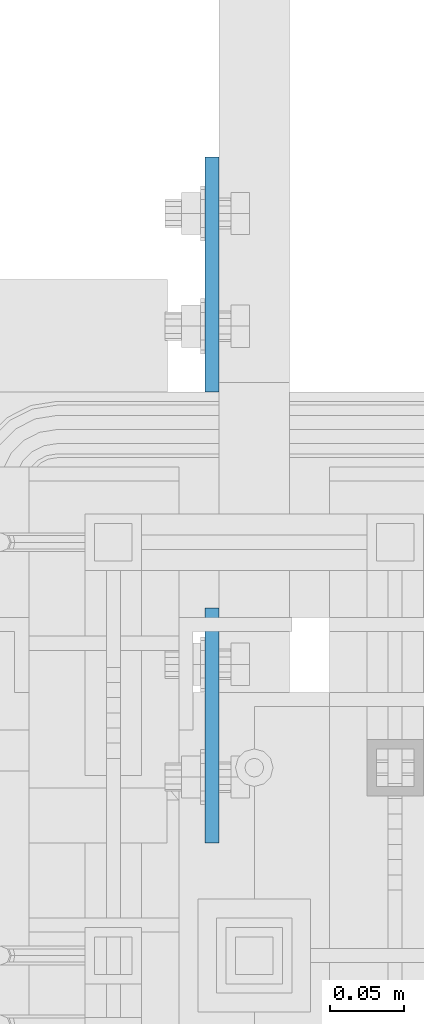
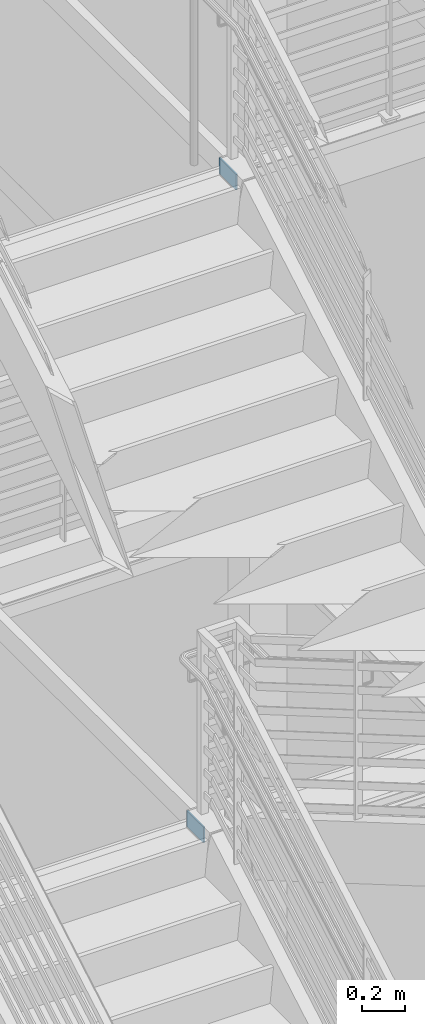
# One storey, part 1056 of 1179: 2 plates, 2 elements without a shape of their own.
"""IFC2X3 building model written with IfcOpenShell, lengths in millimetres."""

from ifc_helpers import new_model, si_unit, frame, origin_with_axes, place, context, subcontext, project, spatial, faceted_brep, material, type_object, element, aggregate, save


model = new_model("IFC2X3")

# Units and contexts
model_context = context("Model", 3, precision=1e-05, world=origin_with_axes())
body_context = subcontext(model_context, "Body", "Model", "MODEL_VIEW")
ifc_project = project(units=[si_unit("LENGTHUNIT", "METRE", prefix="MILLI"), si_unit("AREAUNIT", "SQUARE_METRE"), si_unit("VOLUMEUNIT", "CUBIC_METRE"), si_unit("MASSUNIT", "GRAM", prefix="KILO"), si_unit("TIMEUNIT", "SECOND"), si_unit("PLANEANGLEUNIT", "RADIAN"), si_unit("SOLIDANGLEUNIT", "STERADIAN"), si_unit("THERMODYNAMICTEMPERATUREUNIT", "DEGREE_CELSIUS"), si_unit("LUMINOUSINTENSITYUNIT", "LUMEN")], contexts=[model_context])

# Site, building, storey
site_placement = place(None, origin_with_axes())
site = spatial("IfcSite", under=ifc_project, at=site_placement, CompositionType="ELEMENT")
building_placement = place(site_placement, origin_with_axes())
building = spatial("IfcBuilding", under=site, at=building_placement, Name="Undefined", CompositionType="ELEMENT")
storey_placement = place(building_placement, origin_with_axes())
storey = spatial("IfcBuildingStorey", under=building, at=storey_placement, Name="Undefined", CompositionType="ELEMENT", Elevation=0.0)

# Assembly, plate
assembly_1_placement = place(storey_placement, origin_with_axes())
assembly_1 = element("IfcElementAssembly", 1, at=assembly_1_placement, inside=storey, Name="BEAM", AssemblyPlace="NOTDEFINED", PredefinedType="RIGID_FRAME")
ifc_material = material(Name="STEEL/A36")
plate_type = type_object("IfcPlateType", PredefinedType="NOTDEFINED")
plate_1_placement = place(assembly_1_placement, frame((-1781.175, 35496.5000000027, 4114.8), z_axis=(0.0, 1.0, 0.0), x_axis=(0.0, 0.0, -1.0)))
plate_1 = element("IfcPlate", 2, at=plate_1_placement, type_object=plate_type, material=ifc_material, Name="PLATE", context=body_context, shape_type="Brep", body=[
    faceted_brep([(0.0, -4.76249999999709, 0.0), (0.0, -4.76250000000005, 158.75), (0.0, 4.76250000000005, 158.75), (0.0, 4.76249999999709, 0.0), (88.8999999999996, -4.76250000000005, 158.75), (88.8999999999996, 4.76250000000005, 158.75), (88.8999999999996, -4.76250000000005, 0.0), (88.8999999999996, 4.76250000000005, 0.0)], [[[0, 1, 2, 3]], [[1, 4, 5, 2]], [[4, 6, 7, 5]], [[6, 0, 3, 7]], [[5, 7, 3, 2]], [[6, 4, 1, 0]]]),
])
aggregate(assembly_1, [plate_1])

assembly_2_placement = place(storey_placement, origin_with_axes())
assembly_2 = element("IfcElementAssembly", 3, at=assembly_2_placement, inside=storey, Name="BEAM", AssemblyPlace="NOTDEFINED", PredefinedType="RIGID_FRAME")
plate_2_placement = place(assembly_2_placement, frame((-1781.175, 35191.7, 8026.4), z_axis=(0.0, 1.0, 0.0), x_axis=(0.0, 0.0, -1.0)))
plate_2 = element("IfcPlate", 4, at=plate_2_placement, type_object=plate_type, material=ifc_material, Name="PLATE", context=body_context, shape_type="Brep", body=[
    faceted_brep([(0.0, -4.76249999999709, 0.0), (0.0, -4.76250000000005, 158.75), (0.0, 4.76250000000005, 158.75), (0.0, 4.76249999999709, 0.0), (88.8999999999996, -4.76250000000005, 158.75), (88.8999999999996, 4.76250000000005, 158.75), (88.8999999999996, -4.76250000000005, 0.0), (88.8999999999996, 4.76250000000005, 0.0)], [[[0, 1, 2, 3]], [[1, 4, 5, 2]], [[4, 6, 7, 5]], [[6, 0, 3, 7]], [[5, 7, 3, 2]], [[6, 4, 1, 0]]]),
])
aggregate(assembly_2, [plate_2])

save(model, "model.ifc")
